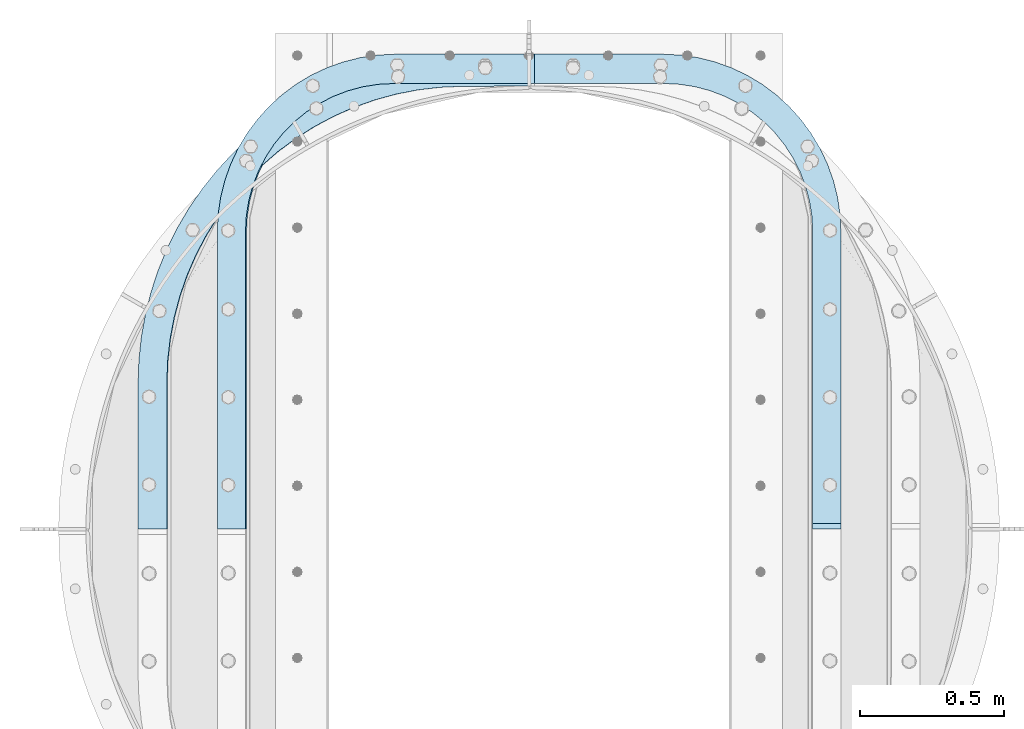
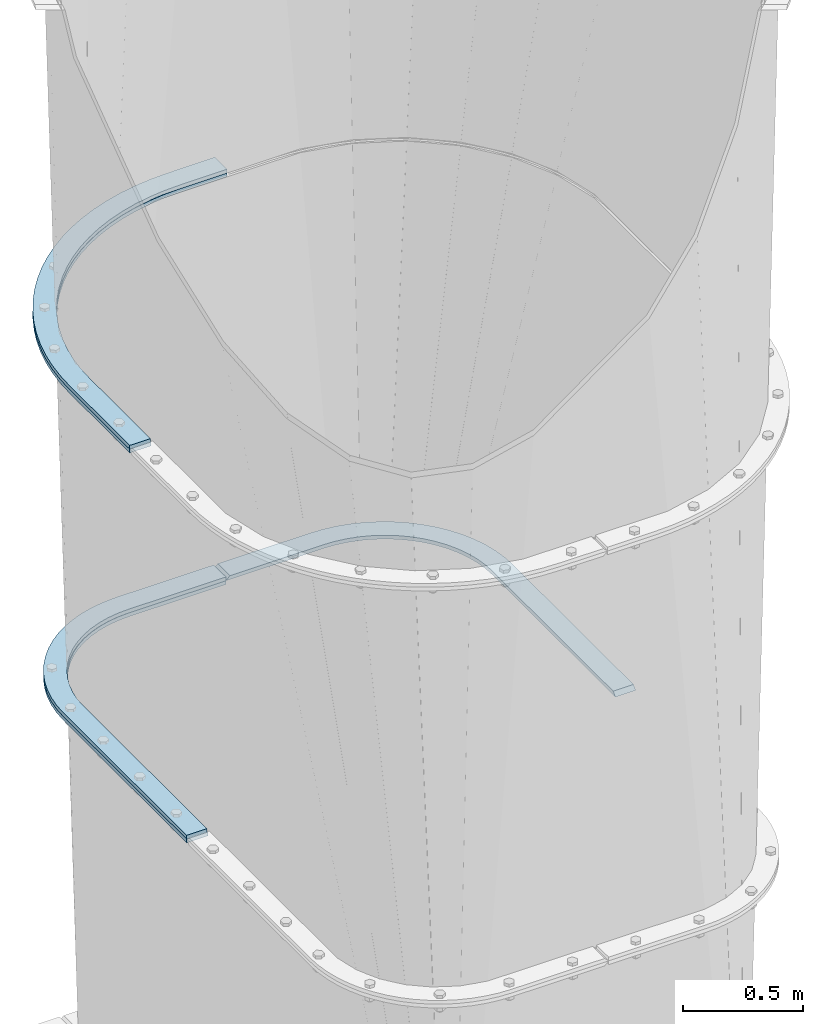
# One storey, part 13 of 15: 5 plates, 3 elements without a shape of their own.
"""IFC2X3 building model written with IfcOpenShell, lengths in millimetres."""

import ifcopenshell
import ifcopenshell.guid

model = None  # the IFC model being written
_history = None  # IfcOwnerHistory: only IFC2X3 demands one
_inside = {}  # id of a spatial element -> (the spatial element, [elements in it])
_under = {}  # id of a project, library or spatial element -> (it, [spatial elements below it])
_declared = {}  # id of a project -> (the project, [libraries it declares])
_typed = {}  # id of a type object -> (the type object, [elements of that type])
_made_of = {}  # id of a material, layer set ... -> (it, [elements and type objects made of it])


def new_model(schema):
    """Start an empty IFC model of exactly this schema.

    Asked for "IFC4X3", IfcOpenShell would pick the latest addendum, in which some entities
    have other attributes; the version numbers below select the first issue.
    IFC2X3 requires an IfcOwnerHistory on every rooted entity: one is made here for all.
    """
    global model, _history
    if schema == "IFC4X3":
        model = ifcopenshell.file(schema_version=(4, 3, 0, 0))
    else:
        model = ifcopenshell.file(schema=schema)
    _inside.clear()
    _under.clear()
    _declared.clear()
    _typed.clear()
    _made_of.clear()
    _history = None
    if model.schema == "IFC2X3":
        org = make("IfcOrganization", Name="unknown")
        user = make(
            "IfcPersonAndOrganization",
            ThePerson=make("IfcPerson", FamilyName="unknown"),
            TheOrganization=org,
        )
        app = make(
            "IfcApplication",
            ApplicationDeveloper=org,
            Version="unknown",
            ApplicationFullName="unknown",
            ApplicationIdentifier="unknown",
        )
        _history = make(
            "IfcOwnerHistory",
            OwningUser=user,
            OwningApplication=app,
            ChangeAction="ADDED",
            CreationDate=0,
        )
    return model


def make(cls, **values):
    """One entity of the class cls with the attributes given. An attribute that is None is left unset."""
    return model.create_entity(
        cls, **{name: value for name, value in values.items() if value is not None}
    )


def rooted(cls, **values):
    """An entity with a GlobalId (a new one), such as an element, a storey or a relation."""
    return make(cls, GlobalId=ifcopenshell.guid.new(), OwnerHistory=_history, **values)


def si_unit(unit_type, name, prefix=None):
    """IfcSIUnit, for example si_unit("LENGTHUNIT", "METRE", prefix="MILLI")."""
    return make("IfcSIUnit", UnitType=unit_type, Prefix=prefix, Name=name)


def assignment(units):
    """IfcUnitAssignment: the units of a project."""
    return None if units is None else make("IfcUnitAssignment", Units=units)


def point(xyz):
    """IfcCartesianPoint."""
    return None if xyz is None else make("IfcCartesianPoint", Coordinates=xyz)


def direction(xyz):
    """IfcDirection."""
    return None if xyz is None else make("IfcDirection", DirectionRatios=xyz)


def frame(location, z_axis=None, x_axis=None):
    """IfcAxis2Placement3D, a coordinate frame: its origin and axes. An axis left out is left unset."""
    return make(
        "IfcAxis2Placement3D",
        Location=point(location),
        Axis=direction(z_axis),
        RefDirection=direction(x_axis),
    )


def origin_with_axes():
    """The frame at (0, 0, 0) with the z axis (0, 0, 1) and the x axis (1, 0, 0) written out."""
    return frame((0.0, 0.0, 0.0), z_axis=(0.0, 0.0, 1.0), x_axis=(1.0, 0.0, 0.0))


def place(relative_to, where):
    """IfcLocalPlacement: puts the frame where relative to a parent placement (None: the world)."""
    return make(
        "IfcLocalPlacement", PlacementRelTo=relative_to, RelativePlacement=where
    )


def context(
    kind, dimensions, precision=None, world=None, true_north=None, identifier=None
):
    """IfcGeometricRepresentationContext, for example the 3D "Model" context."""
    return make(
        "IfcGeometricRepresentationContext",
        ContextIdentifier=identifier,
        ContextType=kind,
        CoordinateSpaceDimension=dimensions,
        Precision=precision,
        WorldCoordinateSystem=world,
        TrueNorth=true_north,
    )


def subcontext(parent, identifier, kind, view, scale=None):
    """IfcGeometricRepresentationSubContext, for example "Body" below "Model"."""
    return make(
        "IfcGeometricRepresentationSubContext",
        ContextIdentifier=identifier,
        ContextType=kind,
        ParentContext=parent,
        TargetScale=scale,
        TargetView=view,
    )


def project(units=None, contexts=None):
    """IfcProject with its units and contexts."""
    return rooted(
        "IfcProject",
        Name="project",
        RepresentationContexts=contexts,
        UnitsInContext=assignment(units),
    )


def spatial(cls, under=None, at=None, **own):
    """A site, building, storey or space (cls), placed at a placement, below another one or the project."""
    s = rooted(cls, ObjectPlacement=at, **own)
    if under is not None:
        _under.setdefault(under.id(), (under, []))[1].append(s)
    return s


def faces_of(points, faces, orient=None, outer=None):
    """IfcFace entities. A face is a list of loops; a loop is a list of indices into points, from 0.

    orient and outer hold one flag for each loop. By default every Orientation is true, the
    first loop of a face is its IfcFaceOuterBound and the others are IfcFaceBound.
    """
    made = []
    for i, loops in enumerate(faces):
        bounds = []
        for j, loop in enumerate(loops):
            is_outer = j == 0 if outer is None else outer[i][j]
            bounds.append(
                make(
                    "IfcFaceOuterBound" if is_outer else "IfcFaceBound",
                    Bound=make("IfcPolyLoop", Polygon=[points[k] for k in loop]),
                    Orientation=True if orient is None else orient[i][j],
                )
            )
        made.append(make("IfcFace", Bounds=bounds))
    return made


def faceted_brep(points, faces, orient=None, outer=None, voids=None):
    """IfcFacetedBrep: a solid bounded by flat faces; with voids (closed shells), ...WithVoids."""
    shared = [point(p) for p in points]
    hull = make("IfcClosedShell", CfsFaces=faces_of(shared, faces, orient, outer))
    if voids is None:
        return make("IfcFacetedBrep", Outer=hull)
    return make(
        "IfcFacetedBrepWithVoids",
        Outer=hull,
        Voids=[
            make(cls, CfsFaces=faces_of(shared, fs, o, b)) for cls, fs, o, b in voids
        ],
    )


def shape(context_of_items, identifier, shape_type, items):
    """IfcShapeRepresentation: the items that make up one representation, for example the "Body"."""
    return make(
        "IfcShapeRepresentation",
        ContextOfItems=context_of_items,
        RepresentationIdentifier=identifier,
        RepresentationType=shape_type,
        Items=items,
    )


def material(Name=None, Category=None):
    """IfcMaterial."""
    return make("IfcMaterial", Name=Name, Category=Category)


def made_of(thing, what):
    """Note that an element or type object is made of a material, layer set ...; save() writes the relation."""
    if what is not None:
        _made_of.setdefault(what.id(), (what, []))[1].append(thing)
    return thing


def type_object(cls, material=None, **own):
    """A type object (cls), such as IfcWallType, which elements share."""
    return made_of(rooted(cls, **own), material)


def element(
    cls,
    number,
    at=None,
    inside=None,
    cuts=None,
    type_object=None,
    material=None,
    context=None,
    identifier="Body",
    shape_type=None,
    held_by="IfcProductDefinitionShape",
    body=None,
    shapes=None,
    **own,
):
    """One element of the class cls, such as IfcWall. Its Tag is "e" and its number.

    at: its placement. inside: the storey or other place that contains it. cuts: it is an
    opening in that element (IfcRelVoidsElement). A single representation is given by context,
    identifier, shape_type and body (its items); several are given by shapes. held_by: the class
    of the entity that holds the representations. save() writes the other relations.
    """
    e = rooted(cls, Tag="e%d" % number, ObjectPlacement=at, **own)
    if body is not None:
        shapes = [shape(context, identifier, shape_type, body)]
    if shapes is not None:
        e.Representation = make(held_by, Representations=shapes)
    if inside is not None:
        _inside.setdefault(inside.id(), (inside, []))[1].append(e)
    if cuts is not None:
        rooted(
            "IfcRelVoidsElement", RelatingBuildingElement=cuts, RelatedOpeningElement=e
        )
    if type_object is not None:
        _typed.setdefault(type_object.id(), (type_object, []))[1].append(e)
    return made_of(e, material)


def aggregate(whole, parts):
    """IfcRelAggregates: a whole, such as a stair, and the parts it consists of."""
    return rooted("IfcRelAggregates", RelatingObject=whole, RelatedObjects=parts)


def save(model, path):
    """Write the relations noted so far, then the file.

    IfcRelAggregates (storeys below a building ...), IfcRelContainedInSpatialStructure (elements
    in a storey), IfcRelDefinesByType, IfcRelAssociatesMaterial and IfcRelDeclares: one each for
    every whole, place, type object, material and project.
    """
    for whole, parts in _under.values():
        aggregate(whole, parts)
    for where, things in _inside.values():
        rooted(
            "IfcRelContainedInSpatialStructure",
            RelatedElements=things,
            RelatingStructure=where,
        )
    for kind, things in _typed.values():
        rooted("IfcRelDefinesByType", RelatedObjects=things, RelatingType=kind)
    for what, things in _made_of.values():
        rooted("IfcRelAssociatesMaterial", RelatedObjects=things, RelatingMaterial=what)
    for by, libraries in _declared.values():
        rooted("IfcRelDeclares", RelatingContext=by, RelatedDefinitions=libraries)
    model.write(path)


model = new_model("IFC2X3")

# Units and contexts
model_context = context("Model", 3, precision=1e-05, world=origin_with_axes())
body_context = subcontext(model_context, "Body", "Model", "MODEL_VIEW")
ifc_project = project(units=[si_unit("LENGTHUNIT", "METRE", prefix="MILLI"), si_unit("AREAUNIT", "SQUARE_METRE"), si_unit("VOLUMEUNIT", "CUBIC_METRE"), si_unit("MASSUNIT", "GRAM", prefix="KILO"), si_unit("TIMEUNIT", "SECOND"), si_unit("PLANEANGLEUNIT", "RADIAN"), si_unit("SOLIDANGLEUNIT", "STERADIAN"), si_unit("THERMODYNAMICTEMPERATUREUNIT", "DEGREE_CELSIUS"), si_unit("LUMINOUSINTENSITYUNIT", "LUMEN")], contexts=[model_context])

# Site, building, storey
site_placement = place(None, origin_with_axes())
site = spatial("IfcSite", under=ifc_project, at=site_placement, CompositionType="ELEMENT")
building_placement = place(site_placement, origin_with_axes())
building = spatial("IfcBuilding", under=site, at=building_placement, Name="Undefined", CompositionType="ELEMENT")
storey_placement = place(building_placement, origin_with_axes())
storey = spatial("IfcBuildingStorey", under=building, at=storey_placement, Name="Undefined", CompositionType="ELEMENT", Elevation=0.0)

# Assembly, plate
assembly_1_placement = place(storey_placement, origin_with_axes())
assembly_1 = element("IfcElementAssembly", 1, at=assembly_1_placement, inside=storey, Name="TRANSITION", AssemblyPlace="NOTDEFINED", PredefinedType="RIGID_FRAME")
ifc_material = material(Name="STEEL/A36")
plate_type_1 = type_object("IfcPlateType", PredefinedType="NOTDEFINED")
plate_1_placement = place(assembly_1_placement, frame((-476.623078132654, 1720.87907416661, 4192.06000019074), z_axis=(0.0, 1.0, 0.0), x_axis=(1.0, 0.0, 0.0)))
plate_1 = element("IfcPlate", 2, at=plate_1_placement, type_object=plate_type_1, material=ifc_material, Name="PLATE", context=body_context, shape_type="Brep", body=[
    faceted_brep([(0.0, -9.52499999999964, 0.0), (0.00226665040457874, -9.52499999999964, 506.568496906642), (0.00226665040457874, 9.52499999999964, 506.568496906642), (0.0, 9.52499999999964, 0.0), (2.86552112687696, -9.52499999999964, 586.965399212112), (2.86552112687696, 9.52499999999964, 586.965399212112), (11.4400606208065, -9.52499999999964, 666.955007280796), (11.4400606208065, 9.52499999999964, 666.955007280796), (25.682448871113, -9.52499999999964, 746.132115736726), (25.682448871113, 9.52499999999964, 746.132115736726), (45.5205378522613, -9.52499999999964, 824.095635103739), (45.5205378522613, 9.52499999999964, 824.095635103739), (70.8538332563299, -9.52499999999964, 900.450623614542), (70.8538332563299, 9.52499999999964, 900.450623614542), (101.554003569561, -9.52499999999964, 974.810287877187), (101.554003569561, 9.52499999999964, 974.810287877187), (137.465530164548, -9.52499999999964, 1046.79794226412), (137.465530164548, 9.52499999999964, 1046.79794226412), (178.406495114871, -9.52499999999964, 1116.04891709806), (178.406495114871, 9.52499999999964, 1116.04891709806), (224.169502741328, -9.52499999999964, 1182.2124059684), (224.169502741328, 9.52499999999964, 1182.2124059684), (274.522730221457, -9.52499999999964, 1244.95324282008), (274.522730221457, 9.52499999999964, 1244.95324282008), (329.211101940261, -9.52499999999964, 1303.95359981273), (329.211101940261, 9.52499999999964, 1303.95359981273), (387.957581633183, -9.52499999999964, 1358.9145973492), (387.957581633183, 9.52499999999964, 1358.9145973492), (450.464575775707, -9.52499999999964, 1409.55781811744), (450.464575775707, 9.52499999999964, 1409.55781811744), (516.41544111038, -9.52499999999964, 1455.62671747614), (516.41544111038, 9.52499999999964, 1455.62671747614), (585.476088674554, -9.52499999999964, 1496.88792303938), (585.476088674554, 9.52499999999964, 1496.88792303938), (657.296676203268, -9.52499999999964, 1533.13241687699), (657.296676203268, 9.52499999999964, 1533.13241687699), (731.513380334047, -9.52499999999964, 1564.176594342), (731.513380334047, 9.52499999999964, 1564.176594342), (807.750239636084, -9.52499999999964, 1589.86319416129), (807.750239636084, 9.52499999999964, 1589.86319416129), (885.621059127542, -9.52499999999964, 1610.062095078), (885.621059127542, 9.52499999999964, 1610.062095078), (964.731366633227, -9.52499999999964, 1624.6709750101), (964.731366633227, 9.52499999999964, 1624.6709750101), (1044.68041107224, -9.52499999999964, 1633.61582938589), (1044.68041107224, 9.52499999999964, 1633.61582938589), (1125.06319255282, -9.52499999999964, 1636.85134603082), (1125.06319255282, 9.52499999999964, 1636.85134603082), (1356.09802246094, -9.52499999999964, 1637.92224121094), (1356.09802246094, 9.52499999999964, 1637.92224121094), (1356.09802246094, -9.52499999999964, 1536.322265625), (1356.09802246094, 9.52499999999964, 1536.322265625), (1123.73482538487, -9.52499999999964, 1535.24674210153), (1123.73482538487, 9.52499999999964, 1535.24674210153), (1047.10030478318, -9.52499999999964, 1532.03247607219), (1047.10030478318, 9.52499999999964, 1532.03247607219), (970.918303938195, -9.52499999999964, 1523.11709603465), (970.918303938195, 9.52499999999964, 1523.11709603465), (895.612355762711, -9.52499999999964, 1508.55016693653), (895.612355762711, 9.52499999999964, 1508.55016693653), (821.601122765285, -9.52499999999964, 1488.41267344407), (821.601122765285, 9.52499999999964, 1488.41267344407), (749.2960695011, -9.52499999999964, 1462.8165697089), (749.2960695011, 9.52499999999964, 1462.8165697089), (679.099175039733, -9.52499999999964, 1431.90415696032), (679.099175039733, 9.52499999999964, 1431.90415696032), (611.400698167385, -9.52499999999964, 1395.84729238334), (611.400698167385, 9.52499999999964, 1395.84729238334), (546.57700774787, -9.52499999999964, 1354.84643368071), (546.57700774787, 9.52499999999964, 1354.84643368071), (484.988490304467, -9.52499999999964, 1309.12952463074), (484.988490304467, 9.52499999999964, 1309.12952463074), (426.977546455406, -9.52499999999964, 1258.95072783668), (426.977546455406, 9.52499999999964, 1258.95072783668), (372.866687341763, -9.52499999999964, 1204.58901171272), (372.866687341763, 9.52499999999964, 1204.58901171272), (322.956741630674, -9.52499999999964, 1146.34659956251), (322.956741630674, 9.52499999999964, 1146.34659956251), (277.525183061995, -9.52499999999964, 1084.54728937235), (277.525183061995, 9.52499999999964, 1084.54728937235), (236.824587836399, -9.52499999999964, 1019.5346536602), (236.824587836399, 9.52499999999964, 1019.5346536602), (201.081230421042, -9.52499999999964, 951.670129388405), (201.081230421042, 9.52499999999964, 951.670129388405), (170.493825579402, -9.52499999999964, 881.331008559293), (170.493825579402, 9.52499999999964, 881.331008559293), (145.232423618945, -9.52499999999964, 808.908340664835), (145.232423618945, 9.52499999999964, 808.908340664835), (125.437464998504, -9.52499999999964, 734.804758651724), (125.437464998504, 9.52499999999964, 734.804758651724), (111.218999551242, -9.52499999999964, 659.432240488378), (111.218999551242, 9.52499999999964, 659.432240488378), (102.656074663938, -9.52499999999964, 583.209818778404), (102.656074663938, 9.52499999999964, 583.209818778404), (99.7962958139181, -9.52499999999964, 506.561251153978), (99.7962958139181, 9.52499999999964, 506.561251153978), (99.7946014404297, -9.52499999999964, 0.0), (99.7946014404297, 9.52499999999964, 0.0)], [[[0, 1, 2, 3]], [[1, 4, 5, 2]], [[4, 6, 7, 5]], [[6, 8, 9, 7]], [[8, 10, 11, 9]], [[10, 12, 13, 11]], [[12, 14, 15, 13]], [[14, 16, 17, 15]], [[16, 18, 19, 17]], [[18, 20, 21, 19]], [[20, 22, 23, 21]], [[22, 24, 25, 23]], [[24, 26, 27, 25]], [[26, 28, 29, 27]], [[28, 30, 31, 29]], [[30, 32, 33, 31]], [[32, 34, 35, 33]], [[34, 36, 37, 35]], [[36, 38, 39, 37]], [[38, 40, 41, 39]], [[40, 42, 43, 41]], [[42, 44, 45, 43]], [[44, 46, 47, 45]], [[46, 48, 49, 47]], [[48, 50, 51, 49]], [[50, 52, 53, 51]], [[52, 54, 55, 53]], [[54, 56, 57, 55]], [[56, 58, 59, 57]], [[58, 60, 61, 59]], [[60, 62, 63, 61]], [[62, 64, 65, 63]], [[64, 66, 67, 65]], [[66, 68, 69, 67]], [[68, 70, 71, 69]], [[70, 72, 73, 71]], [[72, 74, 75, 73]], [[74, 76, 77, 75]], [[76, 78, 79, 77]], [[78, 80, 81, 79]], [[80, 82, 83, 81]], [[82, 84, 85, 83]], [[84, 86, 87, 85]], [[86, 88, 89, 87]], [[88, 90, 91, 89]], [[90, 92, 93, 91]], [[92, 94, 95, 93]], [[94, 96, 97, 95]], [[96, 0, 3, 97]], [[5, 7, 9, 11, 13, 15, 17, 19, 21, 23, 25, 27, 29, 31, 33, 35, 37, 39, 41, 43, 45, 47, 49, 51, 53, 55, 57, 59, 61, 63, 65, 67, 69, 71, 73, 75, 77, 79, 81, 83, 85, 87, 89, 91, 93, 95, 97, 3, 2]], [[96, 94, 92, 90, 88, 86, 84, 82, 80, 78, 76, 74, 72, 70, 68, 66, 64, 62, 60, 58, 56, 54, 52, 50, 48, 46, 44, 42, 40, 38, 36, 34, 32, 30, 28, 26, 24, 22, 20, 18, 16, 14, 12, 10, 8, 6, 4, 1, 0]]]),
])
aggregate(assembly_1, [plate_1])

# Assembly, plates
assembly_2_placement = place(storey_placement, origin_with_axes())
assembly_2 = element("IfcElementAssembly", 3, at=assembly_2_placement, inside=storey, Name="TRANSITION", AssemblyPlace="NOTDEFINED", PredefinedType="RIGID_FRAME")
plate_2_placement = place(assembly_2_placement, frame((-476.623078132654, 1720.87907416661, 4173.01), z_axis=(0.0, 1.0, 0.0), x_axis=(1.0, 0.0, 0.0)))
plate_2 = element("IfcPlate", 4, at=plate_2_placement, type_object=plate_type_1, material=ifc_material, Name="PLATE", context=body_context, shape_type="Brep", body=[
    faceted_brep([(0.0, -9.52499999999964, 0.0), (0.00226665040457874, -9.52499999999964, 506.568496906642), (0.00226665040457874, 9.52499999999964, 506.568496906642), (0.0, 9.52499999999964, 0.0), (2.86552112687696, -9.52499999999964, 586.965399212112), (2.86552112687696, 9.52499999999964, 586.965399212112), (11.4400606208065, -9.52499999999964, 666.955007280796), (11.4400606208065, 9.52499999999964, 666.955007280796), (25.682448871113, -9.52499999999964, 746.132115736726), (25.682448871113, 9.52499999999964, 746.132115736726), (45.5205378522613, -9.52499999999964, 824.095635103739), (45.5205378522613, 9.52499999999964, 824.095635103739), (70.8538332563299, -9.52499999999964, 900.450623614542), (70.8538332563299, 9.52499999999964, 900.450623614542), (101.554003569561, -9.52499999999964, 974.810287877187), (101.554003569561, 9.52499999999964, 974.810287877187), (137.465530164548, -9.52499999999964, 1046.79794226412), (137.465530164548, 9.52499999999964, 1046.79794226412), (178.406495114871, -9.52499999999964, 1116.04891709806), (178.406495114871, 9.52499999999964, 1116.04891709806), (224.169502741328, -9.52499999999964, 1182.2124059684), (224.169502741328, 9.52499999999964, 1182.2124059684), (274.522730221457, -9.52499999999964, 1244.95324282008), (274.522730221457, 9.52499999999964, 1244.95324282008), (329.211101940261, -9.52499999999964, 1303.95359981273), (329.211101940261, 9.52499999999964, 1303.95359981273), (387.957581633183, -9.52499999999964, 1358.9145973492), (387.957581633183, 9.52499999999964, 1358.9145973492), (450.464575775707, -9.52499999999964, 1409.55781811744), (450.464575775707, 9.52499999999964, 1409.55781811744), (516.41544111038, -9.52499999999964, 1455.62671747614), (516.41544111038, 9.52499999999964, 1455.62671747614), (585.476088674554, -9.52499999999964, 1496.88792303938), (585.476088674554, 9.52499999999964, 1496.88792303938), (657.296676203268, -9.52499999999964, 1533.13241687699), (657.296676203268, 9.52499999999964, 1533.13241687699), (731.513380334047, -9.52499999999964, 1564.176594342), (731.513380334047, 9.52499999999964, 1564.176594342), (807.750239636084, -9.52499999999964, 1589.86319416129), (807.750239636084, 9.52499999999964, 1589.86319416129), (885.621059127542, -9.52499999999964, 1610.062095078), (885.621059127542, 9.52499999999964, 1610.062095078), (964.731366633227, -9.52499999999964, 1624.6709750101), (964.731366633227, 9.52499999999964, 1624.6709750101), (1044.68041107224, -9.52499999999964, 1633.61582938589), (1044.68041107224, 9.52499999999964, 1633.61582938589), (1125.06319255282, -9.52499999999964, 1636.85134603082), (1125.06319255282, 9.52499999999964, 1636.85134603082), (1356.09802246094, -9.52499999999964, 1637.92224121094), (1356.09802246094, 9.52499999999964, 1637.92224121094), (1356.09802246094, -9.52499999999964, 1536.322265625), (1356.09802246094, 9.52499999999964, 1536.322265625), (1125.53337021302, -9.52499999999964, 1535.25353104851), (1125.53337021302, 9.52499999999964, 1535.25353104851), (1048.89919630054, -9.52499999999964, 1532.03878036735), (1048.89919630054, 9.52499999999964, 1532.03878036735), (972.717574464455, -9.52499999999964, 1523.1229670218), (972.717574464455, 9.52499999999964, 1523.1229670218), (897.41203190946, -9.52499999999964, 1508.55565794681), (897.41203190946, 9.52499999999964, 1508.55565794681), (823.401225329481, -9.52499999999964, 1488.41783923252), (823.401225329481, 9.52499999999964, 1488.41783923252), (751.096613410651, -9.52499999999964, 1462.82146588676), (751.096613410651, 9.52499999999964, 1462.82146588676), (680.900169351152, -9.52499999999964, 1431.90883942782), (680.900169351152, 9.52499999999964, 1431.90883942782), (613.202146115094, -9.52499999999964, 1395.85181676761), (613.202146115094, 9.52499999999964, 1395.85181676761), (548.378906844311, -9.52499999999964, 1354.8508547834), (548.378906844311, 9.52499999999964, 1354.8508547834), (486.790832489823, -9.52499999999964, 1309.13389588963), (486.790832489823, 9.52499999999964, 1309.13389588963), (428.780318295328, -9.52499999999964, 1258.95510080566), (428.780318295328, 9.52499999999964, 1258.95510080566), (374.669870271166, -9.52499999999964, 1204.59343556431), (374.669870271166, 9.52499999999964, 1204.59343556431), (324.7603122413, -9.52499999999964, 1146.35112061673), (324.7603122413, 9.52499999999964, 1146.35112061673), (279.32911343112, -9.52499999999964, 1084.55195065581), (279.32911343112, 9.52499999999964, 1084.55195065581), (238.628845893756, -9.52499999999964, 1019.53949449874), (238.628845893756, 9.52499999999964, 1019.53949449874), (202.885780350741, -9.52499999999964, 951.67518503657), (202.885780350741, 9.52499999999964, 951.67518503657), (172.298628253365, -9.52499999999964, 881.336309869553), (172.298628253365, 9.52499999999964, 881.336309869553), (147.037437058154, -9.52499999999964, 808.913913799081), (147.037437058154, 9.52499999999964, 808.913913799081), (127.242644858133, -9.52499999999964, 734.810624837339), (127.242644858133, 9.52499999999964, 734.810624837339), (113.024299625579, -9.52499999999964, 659.438415820769), (113.024299625579, 9.52499999999964, 659.438415820769), (104.461447406857, -9.52499999999964, 583.21631407154), (104.461447406857, 9.52499999999964, 583.21631407154), (101.601692870424, -9.52499999999964, 506.568071840215), (101.601692870424, 9.52499999999964, 506.568071840215), (101.599998474121, -9.52499999999964, 0.0), (101.599998474121, 9.52499999999964, 0.0)], [[[0, 1, 2, 3]], [[1, 4, 5, 2]], [[4, 6, 7, 5]], [[6, 8, 9, 7]], [[8, 10, 11, 9]], [[10, 12, 13, 11]], [[12, 14, 15, 13]], [[14, 16, 17, 15]], [[16, 18, 19, 17]], [[18, 20, 21, 19]], [[20, 22, 23, 21]], [[22, 24, 25, 23]], [[24, 26, 27, 25]], [[26, 28, 29, 27]], [[28, 30, 31, 29]], [[30, 32, 33, 31]], [[32, 34, 35, 33]], [[34, 36, 37, 35]], [[36, 38, 39, 37]], [[38, 40, 41, 39]], [[40, 42, 43, 41]], [[42, 44, 45, 43]], [[44, 46, 47, 45]], [[46, 48, 49, 47]], [[48, 50, 51, 49]], [[50, 52, 53, 51]], [[52, 54, 55, 53]], [[54, 56, 57, 55]], [[56, 58, 59, 57]], [[58, 60, 61, 59]], [[60, 62, 63, 61]], [[62, 64, 65, 63]], [[64, 66, 67, 65]], [[66, 68, 69, 67]], [[68, 70, 71, 69]], [[70, 72, 73, 71]], [[72, 74, 75, 73]], [[74, 76, 77, 75]], [[76, 78, 79, 77]], [[78, 80, 81, 79]], [[80, 82, 83, 81]], [[82, 84, 85, 83]], [[84, 86, 87, 85]], [[86, 88, 89, 87]], [[88, 90, 91, 89]], [[90, 92, 93, 91]], [[92, 94, 95, 93]], [[94, 96, 97, 95]], [[96, 0, 3, 97]], [[5, 7, 9, 11, 13, 15, 17, 19, 21, 23, 25, 27, 29, 31, 33, 35, 37, 39, 41, 43, 45, 47, 49, 51, 53, 55, 57, 59, 61, 63, 65, 67, 69, 71, 73, 75, 77, 79, 81, 83, 85, 87, 89, 91, 93, 95, 97, 3, 2]], [[96, 94, 92, 90, 88, 86, 84, 82, 80, 78, 76, 74, 72, 70, 68, 66, 64, 62, 60, 58, 56, 54, 52, 50, 48, 46, 44, 42, 40, 38, 36, 34, 32, 30, 28, 26, 24, 22, 20, 18, 16, 14, 12, 10, 8, 6, 4, 1, 0]]]),
])
plate_type_2 = type_object("IfcPlateType", PredefinedType="NOTDEFINED")
plate_3_placement = place(assembly_2_placement, frame((-201.964438828887, 3367.72732659698, 2110.315), z_axis=(1.0, 0.0, 0.0), x_axis=(0.0, -1.0, 0.0)))
plate_3 = element("IfcPlate", 5, at=plate_3_placement, type_object=plate_type_2, material=ifc_material, Name="PLATE", context=body_context, shape_type="Brep", body=[
    faceted_brep([(-5.43179524470361e-07, -9.52500000000009, 615.950011663852), (-9.5367431640625e-07, -9.52500000000009, 1081.43933105469), (-1.52587881530053e-06, 9.52500000000009, 1081.43933105469), (-5.43179524470361e-07, 9.52500000000009, 615.950011663852), (101.599998474121, -9.52500000000009, 1081.43933105469), (101.599998474121, 9.52500000000009, 1081.43933105469), (101.599998474121, -9.52500000000009, 612.179878234863), (101.599998474121, 9.52500000000009, 612.179878234863), (104.417661457707, -9.52500000000009, 558.41566570511), (104.417661457707, 9.52500000000009, 558.41566570511), (112.839779503182, -9.52500000000009, 505.240505138718), (112.839779503182, 9.52500000000009, 505.240505138718), (126.7740781228, -9.52500000000009, 453.236994722469), (126.7740781228, 9.52500000000009, 453.236994722469), (146.067890224943, -9.52500000000009, 402.974895798919), (146.067890224943, 9.52500000000009, 402.974895798919), (170.509828766731, -9.52500000000009, 355.004890441895), (170.509828766731, 9.52500000000009, 355.004890441895), (199.832102754696, -9.52500000000009, 309.852548068456), (199.832102754696, 9.52500000000009, 309.852548068456), (233.713451218945, -9.52500000000009, 268.012567190381), (233.713451218945, 9.52500000000009, 268.012567190381), (271.782663015576, -9.52500000000009, 229.94335539375), (271.782663015576, 9.52500000000009, 229.94335539375), (313.622643893651, -9.52500000000009, 196.062006929501), (313.622643893651, 9.52500000000009, 196.062006929501), (358.77498626709, -9.52500000000009, 166.739732941536), (358.77498626709, 9.52500000000009, 166.739732941536), (406.744991624115, -9.52500000000009, 142.297794399747), (406.744991624115, 9.52500000000009, 142.297794399747), (457.007090547665, -9.52500000000009, 123.003982297604), (457.007090547665, 9.52500000000009, 123.003982297604), (509.010600963913, -9.52500000000009, 109.069683677987), (509.010600963913, 9.52500000000009, 109.069683677987), (562.185761530305, -9.52500000000009, 100.647565632512), (562.185761530305, 9.52500000000009, 100.647565632512), (615.949974060059, -9.52500000000009, 97.8299026489258), (615.949974060059, 9.52500000000009, 97.8299026489258), (1646.87729611779, -9.52500114440909, 97.8299026491594), (1646.87731933594, 9.52500000000009, 97.8299026489258), (1646.87731933594, -9.52500000000009, 0.0), (1646.87731933594, 9.52500000000009, 0.0), (615.950011663852, -9.52500000000009, 0.0), (615.950011663852, 9.52500000000009, 0.0), (555.576352915146, -9.52500000000009, 2.96596766171297), (555.576352915146, 9.52500000000009, 2.96596766171297), (495.784125503137, -9.52500000000009, 11.8353067569387), (495.784125503137, 9.52500000000009, 11.8353067569387), (437.149161262912, -9.52500000000009, 26.5226007018123), (437.149161262912, 9.52500000000009, 26.5226007018123), (380.236146952604, -9.52500000000009, 46.8864028269114), (380.236146952604, 9.52500000000009, 46.8864028269114), (325.593186011224, -9.52500000000009, 72.7305985860049), (325.593186011224, 9.52500000000009, 72.7305985860049), (273.746520022929, -9.52500000000009, 103.806294246338), (273.746520022929, 9.52500000000009, 103.806294246338), (225.195460722895, -9.52500000000009, 139.814213871333), (225.195460722895, 9.52500000000009, 139.814213871333), (180.407581352366, -9.52500000000009, 180.40758151146), (180.407581352366, 9.52500000000009, 180.40758151146), (139.814213672743, -9.52500000000009, 225.195460846191), (139.814213672743, 9.52500000000009, 225.195460846191), (103.806294004932, -9.52500000000009, 273.746520114471), (103.806294004932, 9.52500000000009, 273.746520114471), (72.7305982988784, -9.52500000000009, 325.593186075362), (72.7305982988784, 9.52500000000009, 325.593186075362), (46.8864024915977, -9.52500000000009, 380.236146993951), (46.8864024915977, 9.52500000000009, 380.236146993951), (26.5226003163094, -9.52500000000009, 437.149161286301), (26.5226003163094, 9.52500000000009, 437.149161286301), (11.8353063197283, -9.52500000000009, 495.784125513574), (11.8353063197283, 9.52500000000009, 495.784125513574), (2.96596717177431, -9.52500000000009, 555.576352917761), (2.96596717177431, 9.52500000000009, 555.576352917761)], [[[0, 1, 2, 3]], [[1, 4, 5, 2]], [[4, 6, 7, 5]], [[6, 8, 9, 7]], [[8, 10, 11, 9]], [[10, 12, 13, 11]], [[12, 14, 15, 13]], [[14, 16, 17, 15]], [[16, 18, 19, 17]], [[18, 20, 21, 19]], [[20, 22, 23, 21]], [[22, 24, 25, 23]], [[24, 26, 27, 25]], [[26, 28, 29, 27]], [[28, 30, 31, 29]], [[30, 32, 33, 31]], [[32, 34, 35, 33]], [[34, 36, 37, 35]], [[36, 38, 39, 37]], [[38, 40, 41, 39]], [[40, 42, 43, 41]], [[42, 44, 45, 43]], [[44, 46, 47, 45]], [[46, 48, 49, 47]], [[48, 50, 51, 49]], [[50, 52, 53, 51]], [[52, 54, 55, 53]], [[54, 56, 57, 55]], [[56, 58, 59, 57]], [[58, 60, 61, 59]], [[60, 62, 63, 61]], [[62, 64, 65, 63]], [[64, 66, 67, 65]], [[66, 68, 69, 67]], [[68, 70, 71, 69]], [[70, 72, 73, 71]], [[72, 0, 3, 73]], [[5, 7, 9, 11, 13, 15, 17, 19, 21, 23, 25, 27, 29, 31, 33, 35, 37, 39, 41, 43, 45, 47, 49, 51, 53, 55, 57, 59, 61, 63, 65, 67, 69, 71, 73, 3, 2]], [[72, 70, 68, 66, 64, 62, 60, 58, 56, 54, 52, 50, 48, 46, 44, 42, 40, 38, 36, 34, 32, 30, 28, 26, 24, 22, 20, 18, 16, 14, 12, 10, 8, 6, 4, 1, 0]]]),
])

# Assembly, plate
assembly_3_placement = place(storey_placement, origin_with_axes())
assembly_3 = element("IfcElementAssembly", 6, at=assembly_3_placement, inside=storey, Name="TRANSITION", AssemblyPlace="NOTDEFINED", PredefinedType="RIGID_FRAME")
plate_4_placement = place(assembly_3_placement, frame((-201.964438828887, 3367.72732659698, 2091.265), z_axis=(1.0, 0.0, 0.0), x_axis=(0.0, -1.0, 0.0)))
plate_4 = element("IfcPlate", 7, at=plate_4_placement, type_object=plate_type_2, material=ifc_material, Name="PLATE", context=body_context, shape_type="Brep", body=[
    faceted_brep([(-5.43179524470361e-07, -9.52500000000009, 615.950011663852), (-9.5367431640625e-07, -9.52500000000009, 1081.43933105469), (-1.52587881530053e-06, 9.52500000000009, 1081.43933105469), (-5.43179524470361e-07, 9.52500000000009, 615.950011663852), (101.599998474121, -9.52500000000009, 1081.43933105469), (101.599998474121, 9.52500000000009, 1081.43933105469), (101.599998474121, -9.52500000000009, 615.949974060059), (101.599998474121, 9.52500000000009, 615.949974060059), (104.417661457707, -9.52500000000009, 562.185761530306), (104.417661457707, 9.52500000000009, 562.185761530306), (112.839779503182, -9.52500000000009, 509.010600963913), (112.839779503182, 9.52500000000009, 509.010600963913), (126.7740781228, -9.52500000000009, 457.007090547665), (126.7740781228, 9.52500000000009, 457.007090547665), (146.067890224943, -9.52500000000009, 406.744991624115), (146.067890224943, 9.52500000000009, 406.744991624115), (170.509828766731, -9.52500000000009, 358.77498626709), (170.509828766731, 9.52500000000009, 358.77498626709), (199.832102754696, -9.52500000000009, 313.622643893651), (199.832102754696, 9.52500000000009, 313.622643893651), (233.713451218945, -9.52500000000009, 271.782663015577), (233.713451218945, 9.52500000000009, 271.782663015577), (271.782663015576, -9.52500000000009, 233.713451218945), (271.782663015576, 9.52500000000009, 233.713451218945), (313.622643893651, -9.52500000000009, 199.832102754696), (313.622643893651, 9.52500000000009, 199.832102754696), (358.77498626709, -9.52500000000009, 170.509828766731), (358.77498626709, 9.52500000000009, 170.509828766731), (406.744991624115, -9.52500000000009, 146.067890224943), (406.744991624115, 9.52500000000009, 146.067890224943), (457.007090547665, -9.52500000000009, 126.7740781228), (457.007090547665, 9.52500000000009, 126.7740781228), (509.010600963913, -9.52500000000009, 112.839779503182), (509.010600963913, 9.52500000000009, 112.839779503182), (562.185761530305, -9.52500000000009, 104.417661457707), (562.185761530305, 9.52500000000009, 104.417661457707), (615.949974060059, -9.52500000000009, 101.599998474121), (615.949974060059, 9.52500000000009, 101.599998474121), (1646.87731933594, -9.52500000000009, 101.599998474121), (1646.87733404866, 9.52499923706046, 101.599998473973), (1646.87731933594, -9.52500000000009, 0.0), (1646.87731933594, 9.52500000000009, 0.0), (615.950011663852, -9.52500000000009, 0.0), (615.950011663852, 9.52500000000009, 0.0), (555.576352915146, -9.52500000000009, 2.96596766171297), (555.576352915146, 9.52500000000009, 2.96596766171297), (495.784125503137, -9.52500000000009, 11.8353067569387), (495.784125503137, 9.52500000000009, 11.8353067569387), (437.149161262912, -9.52500000000009, 26.5226007018123), (437.149161262912, 9.52500000000009, 26.5226007018123), (380.236146952604, -9.52500000000009, 46.8864028269114), (380.236146952604, 9.52500000000009, 46.8864028269114), (325.593186011224, -9.52500000000009, 72.7305985860049), (325.593186011224, 9.52500000000009, 72.7305985860049), (273.746520022929, -9.52500000000009, 103.806294246338), (273.746520022929, 9.52500000000009, 103.806294246338), (225.195460722895, -9.52500000000009, 139.814213871333), (225.195460722895, 9.52500000000009, 139.814213871333), (180.407581352366, -9.52500000000009, 180.40758151146), (180.407581352366, 9.52500000000009, 180.40758151146), (139.814213672743, -9.52500000000009, 225.195460846191), (139.814213672743, 9.52500000000009, 225.195460846191), (103.806294004932, -9.52500000000009, 273.746520114471), (103.806294004932, 9.52500000000009, 273.746520114471), (72.7305982988784, -9.52500000000009, 325.593186075362), (72.7305982988784, 9.52500000000009, 325.593186075362), (46.8864024915977, -9.52500000000009, 380.236146993951), (46.8864024915977, 9.52500000000009, 380.236146993951), (26.5226003163094, -9.52500000000009, 437.149161286301), (26.5226003163094, 9.52500000000009, 437.149161286301), (11.8353063197283, -9.52500000000009, 495.784125513574), (11.8353063197283, 9.52500000000009, 495.784125513574), (2.96596717177431, -9.52500000000009, 555.576352917761), (2.96596717177431, 9.52500000000009, 555.576352917761)], [[[0, 1, 2, 3]], [[1, 4, 5, 2]], [[4, 6, 7, 5]], [[6, 8, 9, 7]], [[8, 10, 11, 9]], [[10, 12, 13, 11]], [[12, 14, 15, 13]], [[14, 16, 17, 15]], [[16, 18, 19, 17]], [[18, 20, 21, 19]], [[20, 22, 23, 21]], [[22, 24, 25, 23]], [[24, 26, 27, 25]], [[26, 28, 29, 27]], [[28, 30, 31, 29]], [[30, 32, 33, 31]], [[32, 34, 35, 33]], [[34, 36, 37, 35]], [[36, 38, 39, 37]], [[38, 40, 41, 39]], [[40, 42, 43, 41]], [[42, 44, 45, 43]], [[44, 46, 47, 45]], [[46, 48, 49, 47]], [[48, 50, 51, 49]], [[50, 52, 53, 51]], [[52, 54, 55, 53]], [[54, 56, 57, 55]], [[56, 58, 59, 57]], [[58, 60, 61, 59]], [[60, 62, 63, 61]], [[62, 64, 65, 63]], [[64, 66, 67, 65]], [[66, 68, 69, 67]], [[68, 70, 71, 69]], [[70, 72, 73, 71]], [[72, 0, 3, 73]], [[5, 7, 9, 11, 13, 15, 17, 19, 21, 23, 25, 27, 29, 31, 33, 35, 37, 39, 41, 43, 45, 47, 49, 51, 53, 55, 57, 59, 61, 63, 65, 67, 69, 71, 73, 3, 2]], [[72, 70, 68, 66, 64, 62, 60, 58, 56, 54, 52, 50, 48, 46, 44, 42, 40, 38, 36, 34, 32, 30, 28, 26, 24, 22, 20, 18, 16, 14, 12, 10, 8, 6, 4, 1, 0]]]),
])
aggregate(assembly_3, [plate_4])

# Plate
plate_5_placement = place(assembly_2_placement, frame((1960.91443882889, 3367.72732659698, 2110.315), z_axis=(-1.0, 0.0, 0.0), x_axis=(0.0, -1.0, 0.0)))
plate_5 = element("IfcPlate", 8, at=plate_5_placement, type_object=plate_type_2, material=ifc_material, Name="PLATE", context=body_context, shape_type="Brep", body=[
    faceted_brep([(101.599998474121, -9.52499923706046, 1081.43954662555), (101.599998474121, 9.52500000000009, 1062.38933182189), (-9.36874954504674e-07, 9.52500000000009, 1062.38933172029), (-9.5367431640625e-07, -9.52500000000009, 1081.43933105469), (2.96596717177431, -9.52500000000009, 555.576352917761), (-5.43179524470361e-07, -9.52500000000009, 615.950011663852), (-5.43179524470361e-07, 9.52500000000009, 615.950011663852), (2.96596717177431, 9.52500000000009, 555.576352917761), (11.8353063197283, -9.52500000000009, 495.784125513574), (11.8353063197283, 9.52500000000009, 495.784125513574), (26.5226003163094, -9.52500000000009, 437.149161286301), (26.5226003163094, 9.52500000000009, 437.149161286301), (46.8864024915977, -9.52500000000009, 380.236146993951), (46.8864024915977, 9.52500000000009, 380.236146993951), (72.7305982988784, -9.52500000000009, 325.593186075362), (72.7305982988784, 9.52500000000009, 325.593186075362), (103.806294004932, -9.52500000000009, 273.746520114471), (103.806294004932, 9.52500000000009, 273.746520114471), (139.814213672743, -9.52500000000009, 225.195460846191), (139.814213672743, 9.52500000000009, 225.195460846191), (180.407581352366, -9.52500000000009, 180.40758151146), (180.407581352366, 9.52500000000009, 180.40758151146), (225.195460722895, -9.52500000000009, 139.814213871333), (225.195460722895, 9.52500000000009, 139.814213871333), (273.746520022929, -9.52500000000009, 103.806294246338), (273.746520022929, 9.52500000000009, 103.806294246338), (325.593186011224, -9.52500000000009, 72.7305985860049), (325.593186011224, 9.52500000000009, 72.7305985860049), (380.236146952604, -9.52500000000009, 46.8864028269114), (380.236146952604, 9.52500000000009, 46.8864028269114), (437.149161262912, -9.52500000000009, 26.5226007018123), (437.149161262912, 9.52500000000009, 26.5226007018123), (495.784125503137, -9.52500000000009, 11.8353067569387), (495.784125503137, 9.52500000000009, 11.8353067569387), (555.576352915146, -9.52500000000009, 2.96596766171297), (555.576352915146, 9.52500000000009, 2.96596766171297), (615.950011663852, -9.52500000000009, 0.0), (615.950011663852, 9.52500000000009, 0.0), (1627.82732009888, 9.52500000000009, 0.0), (1646.87731933594, -9.52500000000009, 0.0), (1646.87729611779, -9.52500114440909, 97.8299026491594), (1627.82732029037, 9.52500000000009, 97.8299026489258), (615.949974060059, 9.52500000000009, 97.8299026489258), (615.949974060059, -9.52500000000009, 97.8299026489258), (562.185761530305, -9.52500000000009, 100.647565632512), (562.185761530305, 9.52500000000009, 100.647565632512), (509.010600963913, -9.52500000000009, 109.069683677987), (509.010600963913, 9.52500000000009, 109.069683677987), (457.007090547665, -9.52500000000009, 123.003982297604), (457.007090547665, 9.52500000000009, 123.003982297604), (406.744991624115, -9.52500000000009, 142.297794399747), (406.744991624115, 9.52500000000009, 142.297794399747), (358.77498626709, -9.52500000000009, 166.739732941536), (358.77498626709, 9.52500000000009, 166.739732941536), (313.622643893651, -9.52500000000009, 196.062006929501), (313.622643893651, 9.52500000000009, 196.062006929501), (271.782663015576, -9.52500000000009, 229.94335539375), (271.782663015576, 9.52500000000009, 229.94335539375), (233.713451218945, -9.52500000000009, 268.012567190381), (233.713451218945, 9.52500000000009, 268.012567190381), (199.832102754696, -9.52500000000009, 309.852548068456), (199.832102754696, 9.52500000000009, 309.852548068456), (170.509828766731, -9.52500000000009, 355.004890441895), (170.509828766731, 9.52500000000009, 355.004890441895), (146.067890224943, -9.52500000000009, 402.974895798919), (146.067890224943, 9.52500000000009, 402.974895798919), (126.7740781228, -9.52500000000009, 453.236994722469), (126.7740781228, 9.52500000000009, 453.236994722469), (112.839779503182, -9.52500000000009, 505.240505138718), (112.839779503182, 9.52500000000009, 505.240505138718), (104.417661457707, -9.52500000000009, 558.41566570511), (104.417661457707, 9.52500000000009, 558.41566570511), (101.599998474121, -9.52500000000009, 612.179878234863), (101.599998474121, 9.52500000000009, 612.179878234863)], [[[0, 1, 2, 3]], [[4, 5, 6, 7]], [[8, 4, 7, 9]], [[10, 8, 9, 11]], [[12, 10, 11, 13]], [[14, 12, 13, 15]], [[16, 14, 15, 17]], [[18, 16, 17, 19]], [[20, 18, 19, 21]], [[22, 20, 21, 23]], [[24, 22, 23, 25]], [[26, 24, 25, 27]], [[28, 26, 27, 29]], [[30, 28, 29, 31]], [[32, 30, 31, 33]], [[34, 32, 33, 35]], [[36, 34, 35, 37]], [[36, 37, 38, 39]], [[40, 39, 38, 41]], [[42, 43, 40, 41]], [[44, 43, 42, 45]], [[46, 44, 45, 47]], [[48, 46, 47, 49]], [[50, 48, 49, 51]], [[52, 50, 51, 53]], [[54, 52, 53, 55]], [[56, 54, 55, 57]], [[58, 56, 57, 59]], [[60, 58, 59, 61]], [[62, 60, 61, 63]], [[64, 62, 63, 65]], [[66, 64, 65, 67]], [[68, 66, 67, 69]], [[70, 68, 69, 71]], [[72, 70, 71, 73]], [[5, 4, 8, 10, 12, 14, 16, 18, 20, 22, 24, 26, 28, 30, 32, 34, 36, 39, 40, 43, 44, 46, 48, 50, 52, 54, 56, 58, 60, 62, 64, 66, 68, 70, 72, 0, 3]], [[6, 5, 3, 2]], [[73, 71, 69, 67, 65, 63, 61, 59, 57, 55, 53, 51, 49, 47, 45, 42, 41, 38, 37, 35, 33, 31, 29, 27, 25, 23, 21, 19, 17, 15, 13, 11, 9, 7, 6, 2, 1]], [[72, 73, 1, 0]]]),
])

aggregate(assembly_2, [plate_2, plate_3, plate_5])

save(model, "model.ifc")
